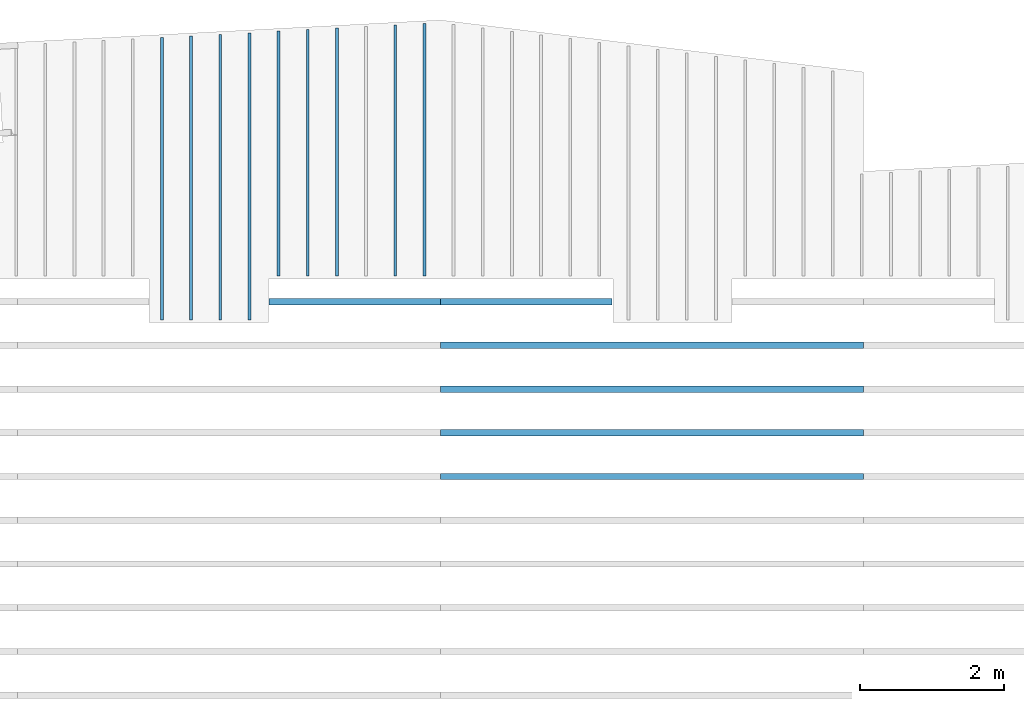
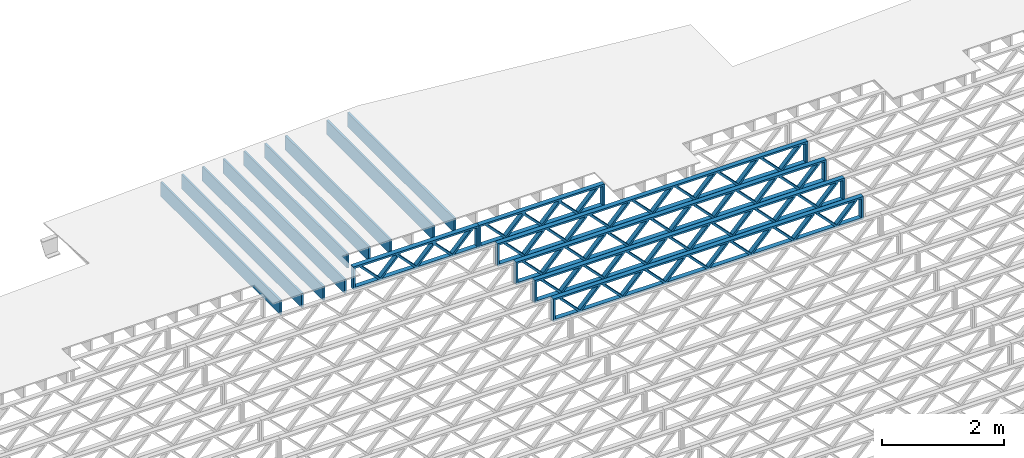
# One storey, part 8 of 13: 15 beams, 3 elements without a shape of their own.
"""IFC4 building model written with IfcOpenShell, lengths in feet."""

from ifc_helpers import new_model, entity, si_unit, converted_unit, derived_unit, direction, frame, frame_2d, origin, origin_2d_with_axis, place, context, subcontext, project, spatial, rectangle, extrude, source, transform, mapped, material, material_profile, profile_set, profile_usage, type_object, type_shapes, element, aggregate, save


model = new_model("IFC4")

# Units and contexts
model_context_1 = context("Model", 3, precision=0.0001, world=origin(), true_north=direction((6.12303176911189e-17, 1.0)))
model_context_2 = context("Model", 3, precision=0.0001, world=origin(), true_north=direction((6.12303176911189e-17, 1.0)))
body_context = subcontext(model_context_2, "Body", "Model", "MODEL_VIEW")
ifc_project = project(units=[converted_unit("LENGTHUNIT", "FOOT", entity("IfcRatioMeasure", 0.3048), si_unit("LENGTHUNIT", "METRE"), dimensions=[1, 0, 0, 0, 0, 0, 0]), converted_unit("AREAUNIT", "SQUARE FOOT", entity("IfcRatioMeasure", 0.09290304), si_unit("AREAUNIT", "SQUARE_METRE"), dimensions=[2, 0, 0, 0, 0, 0, 0]), converted_unit("VOLUMEUNIT", "CUBIC FOOT", entity("IfcRatioMeasure", 0.028316846592), si_unit("VOLUMEUNIT", "CUBIC_METRE"), dimensions=[3, 0, 0, 0, 0, 0, 0]), converted_unit("PLANEANGLEUNIT", "DEGREE", entity("IfcRatioMeasure", 0.0174532925199433), si_unit("PLANEANGLEUNIT", "RADIAN"), dimensions=[0, 0, 0, 0, 0, 0, 0]), si_unit("MASSUNIT", "GRAM", prefix="KILO"), derived_unit("MASSDENSITYUNIT", [(si_unit("MASSUNIT", "GRAM", prefix="KILO"), 1), (si_unit("LENGTHUNIT", "METRE"), -3)]), derived_unit("MOMENTOFINERTIAUNIT", [(si_unit("LENGTHUNIT", "METRE"), 4)]), si_unit("TIMEUNIT", "SECOND"), si_unit("FREQUENCYUNIT", "HERTZ"), si_unit("THERMODYNAMICTEMPERATUREUNIT", "DEGREE_CELSIUS"), derived_unit("THERMALTRANSMITTANCEUNIT", [(si_unit("MASSUNIT", "GRAM", prefix="KILO"), 1), (si_unit("THERMODYNAMICTEMPERATUREUNIT", "KELVIN"), -1), (si_unit("TIMEUNIT", "SECOND"), -3)]), derived_unit("VOLUMETRICFLOWRATEUNIT", [(si_unit("LENGTHUNIT", "METRE"), 3), (si_unit("TIMEUNIT", "SECOND"), -1)]), si_unit("ELECTRICCURRENTUNIT", "AMPERE"), si_unit("ELECTRICVOLTAGEUNIT", "VOLT"), si_unit("POWERUNIT", "WATT"), si_unit("FORCEUNIT", "NEWTON"), si_unit("ILLUMINANCEUNIT", "LUX"), si_unit("LUMINOUSFLUXUNIT", "LUMEN"), si_unit("LUMINOUSINTENSITYUNIT", "CANDELA"), derived_unit("USERDEFINED", [(si_unit("MASSUNIT", "GRAM", prefix="KILO"), -1), (si_unit("LENGTHUNIT", "METRE"), -2), (si_unit("TIMEUNIT", "SECOND"), 3), (si_unit("LUMINOUSFLUXUNIT", "LUMEN"), 1)]), derived_unit("LINEARVELOCITYUNIT", [(si_unit("LENGTHUNIT", "METRE"), 1), (si_unit("TIMEUNIT", "SECOND"), -1)]), si_unit("PRESSUREUNIT", "PASCAL"), derived_unit("USERDEFINED", [(si_unit("LENGTHUNIT", "METRE"), -2), (si_unit("MASSUNIT", "GRAM", prefix="KILO"), 1), (si_unit("TIMEUNIT", "SECOND"), -2)]), derived_unit("LINEARFORCEUNIT", [(si_unit("MASSUNIT", "GRAM", prefix="KILO"), 1), (si_unit("LENGTHUNIT", "METRE"), 1), (si_unit("TIMEUNIT", "SECOND"), -2), (si_unit("LENGTHUNIT", "METRE"), -1)]), derived_unit("PLANARFORCEUNIT", [(si_unit("MASSUNIT", "GRAM", prefix="KILO"), 1), (si_unit("LENGTHUNIT", "METRE"), 1), (si_unit("TIMEUNIT", "SECOND"), -2), (si_unit("LENGTHUNIT", "METRE"), -2)])], contexts=[model_context_1])

# Site, building, storey
site_placement = place(None, origin())
site = spatial("IfcSite", under=ifc_project, at=site_placement, CompositionType="ELEMENT")
building_placement = place(site_placement, origin())
building = spatial("IfcBuilding", under=site, at=building_placement, CompositionType="ELEMENT")
storey_placement = place(building_placement, frame((0.0, 0.0, 21.46875)))
storey = spatial("IfcBuildingStorey", under=building, at=storey_placement, Name="3RD FLOOR", CompositionType="ELEMENT", Elevation=21.46875)

# Assembly, beams
assembly_1_placement = place(storey_placement, origin())
assembly_1 = element("IfcElementAssembly", 1, at=assembly_1_placement, inside=storey, Name="Structural Beam System:Structural Framing System", ObjectType="Structural Beam System:Structural Framing System", AssemblyPlace="NOTDEFINED", PredefinedType="BEAM_GRID")
ifc_material_1 = material(Name="WOOD TRUSS", Category="Materials")
ifc_material_profile_1 = material_profile(ifc_material_1, rectangle(XDim=1.73473973950632, YDim=0.125, at=frame_2d((-1.11022302462516e-16, 8.32667268468867e-17), x_axis=(1.0, 0.0))))
ifc_material_profile_2 = material_profile(ifc_material_1, rectangle(XDim=1.73473973950633, YDim=0.125, at=frame_2d((-1.11022302462516e-16, 8.32667268468867e-17), x_axis=(1.0, 0.0))))
ifc_material_profile_3 = material_profile(ifc_material_1, rectangle(XDim=1.73473973950632, YDim=0.125, at=frame_2d((-5.55111512312578e-17, 1.38777878078145e-16), x_axis=(1.0, 0.0))))
ifc_material_profile_4 = material_profile(ifc_material_1, rectangle(XDim=1.73473973950633, YDim=0.125, at=frame_2d((-1.11022302462516e-16, 8.32667268468867e-17), x_axis=(1.0, 0.0))))
ifc_material_profile_5 = material_profile(ifc_material_1, rectangle(XDim=1.73473973950632, YDim=0.125, at=frame_2d((-1.11022302462516e-16, 8.32667268468867e-17), x_axis=(1.0, 0.0))))
ifc_material_profile_6 = material_profile(ifc_material_1, rectangle(XDim=1.73473973950633, YDim=0.125, at=frame_2d((-2.77555756156289e-16, 3.05311331771918e-16), x_axis=(1.0, 0.0))))
ifc_material_profile_7 = material_profile(ifc_material_1, rectangle(XDim=1.73473973950632, YDim=0.124999999999999, at=frame_2d((-3.88578058618805e-16, -2.4980018054066e-16), x_axis=(1.0, 0.0))))
ifc_material_profile_8 = material_profile(ifc_material_1, rectangle(XDim=1.73473973950633, YDim=0.125, at=frame_2d((2.77555756156289e-16, -3.05311331771918e-16), x_axis=(1.0, 0.0))))
ifc_material_profile_9 = material_profile(ifc_material_1, rectangle(XDim=1.73473973950632, YDim=0.124999999999999, at=frame_2d((-1.11022302462516e-16, 8.32667268468867e-17), x_axis=(1.0, 0.0))))
ifc_material_profile_10 = material_profile(ifc_material_1, rectangle(XDim=1.73473973950633, YDim=0.125, at=origin_2d_with_axis()))
ifc_material_profile_11 = material_profile(ifc_material_1, rectangle(XDim=0.124999999999982, YDim=0.291666666666668, at=origin_2d_with_axis()))
ifc_material_profile_12 = material_profile(ifc_material_1, rectangle(XDim=0.124999999999932, YDim=0.291666666666664, at=origin_2d_with_axis()))
ifc_material_profile_13 = material_profile(ifc_material_1, rectangle(XDim=1.25000000000002, YDim=0.29166666666667, at=origin_2d_with_axis()))
ifc_material_profile_14 = material_profile(ifc_material_1, rectangle(XDim=1.25000000000004, YDim=0.291666666666667, at=origin_2d_with_axis()))
ifc_profile_set_1 = profile_set([ifc_material_profile_1, ifc_material_profile_2, ifc_material_profile_3, ifc_material_profile_4, ifc_material_profile_5, ifc_material_profile_6, ifc_material_profile_7, ifc_material_profile_8, ifc_material_profile_9, ifc_material_profile_10, ifc_material_profile_11, ifc_material_profile_12, ifc_material_profile_13, ifc_material_profile_14])
ifc_profile_usage_1 = profile_usage(ifc_profile_set_1, cardinal=8)
beam_type_1 = type_object("IfcBeamType", PredefinedType="BEAM", material=ifc_profile_set_1)
shared_shape_1 = source(origin(), body_context, "Body", "SweptSolid", [
    extrude(rectangle(XDim=1.73473973950632, YDim=0.124999999999999, at=frame_2d((5.55111512312578e-16, 7.21644966006352e-16), x_axis=(1.0, 0.0))), frame((5.95847627016989, -0.145833333333334, 0.0), z_axis=(0.0, 1.0, 0.0), x_axis=(0.693383046997606, 0.0, 0.720569184836762)), (0.0, 0.0, 1.0), 0.291666666666667),
    extrude(rectangle(XDim=1.73473973950633, YDim=0.125, at=origin_2d_with_axis()), frame((4.70819039649662, -0.145833333333334, 0.0), z_axis=(0.0, 1.0, 0.0), x_axis=(0.69338304699761, 0.0, -0.720569184836758)), (0.0, 0.0, 1.0), 0.291666666666666),
    extrude(rectangle(XDim=1.73473973950632, YDim=0.125, at=frame_2d((2.22044604925031e-16, 3.88578058618805e-16), x_axis=(1.0, 0.0))), frame((3.29180960350342, -0.145833333333334, 0.0), z_axis=(0.0, 1.0, 0.0), x_axis=(0.693383046997606, 0.0, 0.720569184836762)), (0.0, 0.0, 1.0), 0.291666666666667),
    extrude(rectangle(XDim=1.73473973950633, YDim=0.125, at=frame_2d((1.11022302462516e-16, -8.32667268468867e-17), x_axis=(1.0, 0.0))), frame((2.04152372983015, -0.145833333333334, 0.0), z_axis=(0.0, 1.0, 0.0), x_axis=(0.69338304699761, 0.0, -0.720569184836758)), (0.0, 0.0, 1.0), 0.291666666666667),
    extrude(rectangle(XDim=1.73473973950632, YDim=0.125, at=frame_2d((-5.55111512312578e-17, 1.38777878078145e-16), x_axis=(1.0, 0.0))), frame((0.625142936836964, -0.145833333333334, 0.0), z_axis=(0.0, 1.0, 0.0), x_axis=(0.693383046997606, 0.0, 0.720569184836762)), (0.0, 0.0, 1.0), 0.291666666666667),
    extrude(rectangle(XDim=1.73473973950633, YDim=0.125, at=frame_2d((-1.11022302462516e-16, 8.32667268468867e-17), x_axis=(1.0, 0.0))), frame((-0.625142936836306, -0.145833333333334, 0.0), z_axis=(0.0, 1.0, 0.0), x_axis=(0.69338304699761, 0.0, -0.720569184836758)), (0.0, 0.0, 1.0), 0.291666666666667),
    extrude(rectangle(XDim=1.73473973950632, YDim=0.125, at=frame_2d((-1.11022302462516e-16, 8.32667268468867e-17), x_axis=(1.0, 0.0))), frame((-2.0415237298295, -0.145833333333334, 0.0), z_axis=(0.0, 1.0, 0.0), x_axis=(0.693383046997606, 0.0, 0.720569184836762)), (0.0, 0.0, 1.0), 0.291666666666667),
    extrude(rectangle(XDim=1.73473973950633, YDim=0.125, at=origin_2d_with_axis()), frame((-3.29180960350277, -0.145833333333334, 0.0), z_axis=(0.0, 1.0, 0.0), x_axis=(0.69338304699761, 0.0, -0.720569184836758)), (0.0, 0.0, 1.0), 0.291666666666667),
    extrude(rectangle(XDim=1.73473973950632, YDim=0.124999999999999, at=frame_2d((-1.11022302462516e-16, 8.32667268468867e-17), x_axis=(1.0, 0.0))), frame((-4.70819039649596, -0.145833333333334, 0.0), z_axis=(0.0, 1.0, 0.0), x_axis=(0.693383046997606, 0.0, 0.720569184836762)), (0.0, 0.0, 1.0), 0.291666666666667),
    extrude(rectangle(XDim=1.73473973950633, YDim=0.125, at=frame_2d((-5.55111512312578e-16, 6.38378239159465e-16), x_axis=(1.0, 0.0))), frame((-5.95847627016923, -0.145833333333334, 0.0), z_axis=(0.0, 1.0, 0.0), x_axis=(0.69338304699761, 0.0, -0.720569184836758)), (0.0, 0.0, 1.0), 0.291666666666666),
    extrude(rectangle(XDim=1.73473973950632, YDim=0.125, at=frame_2d((-7.21644966006352e-16, -5.82867087928207e-16), x_axis=(1.0, 0.0))), frame((8.62514293683635, -0.145833333333334, 0.0), z_axis=(0.0, 1.0, 0.0), x_axis=(0.693383046997607, 0.0, 0.720569184836761)), (0.0, 0.0, 1.0), 0.291666666666667),
    extrude(rectangle(XDim=1.73473973950633, YDim=0.125, at=origin_2d_with_axis()), frame((7.37485706316307, -0.145833333333334, 0.0), z_axis=(0.0, 1.0, 0.0), x_axis=(0.69338304699761, 0.0, -0.720569184836758)), (0.0, 0.0, 1.0), 0.291666666666666),
    extrude(rectangle(XDim=1.73473973950632, YDim=0.124999999999999, at=frame_2d((-1.11022302462516e-16, 8.32667268468867e-17), x_axis=(1.0, 0.0))), frame((-7.37485706316242, -0.145833333333334, 0.0), z_axis=(0.0, 1.0, 0.0), x_axis=(0.693383046997606, 0.0, 0.720569184836762)), (0.0, 0.0, 1.0), 0.291666666666667),
    extrude(rectangle(XDim=1.73473973950633, YDim=0.125, at=origin_2d_with_axis()), frame((-8.62514293683569, -0.145833333333334, 0.0), z_axis=(0.0, 1.0, 0.0), x_axis=(0.69338304699761, 0.0, -0.720569184836758)), (0.0, 0.0, 1.0), 0.291666666666666),
    extrude(rectangle(XDim=0.124999999999982, YDim=0.291666666666668, at=origin_2d_with_axis()), frame((-9.66666666666596, 0.0, 0.687500000000054), z_axis=(1.0, 0.0, 0.0), x_axis=(0.0, 0.0, -1.0)), (0.0, 0.0, 1.0), 19.3333333333319),
    extrude(rectangle(XDim=0.124999999999932, YDim=0.291666666666664, at=origin_2d_with_axis()), frame((-9.66666666666575, 0.0, -0.687499999999984), z_axis=(1.0, 0.0, 0.0), x_axis=(0.0, 0.0, -1.0)), (0.0, 0.0, 1.0), 19.3333333333317),
    extrude(rectangle(XDim=1.25000000000002, YDim=0.29166666666667, at=origin_2d_with_axis()), frame((9.54166666666594, 0.0, 0.0), z_axis=(1.0, 0.0, 0.0), x_axis=(0.0, 0.0, -1.0)), (0.0, 0.0, 1.0), 0.12500000000002),
    extrude(rectangle(XDim=1.25000000000004, YDim=0.291666666666667, at=origin_2d_with_axis()), frame((-9.66666666666596, 0.0, 0.0), z_axis=(1.0, 0.0, 0.0), x_axis=(0.0, 0.0, -1.0)), (0.0, 0.0, 1.0), 0.125000000000023),
])
type_shapes(beam_type_1, [shared_shape_1])
beam_1_placement = place(assembly_1_placement, frame((-193.404827152229, 955.861934882651, -0.947916666666881)))
beam_1 = element("IfcBeam", 2, at=beam_1_placement, type_object=beam_type_1, material=ifc_profile_usage_1, PredefinedType="BEAM", context=body_context, shape_type="MappedRepresentation", body=[
    mapped(shared_shape_1, transform((0.0, 0.0, 0.0), scale=1.0)),
])
ifc_profile_usage_2 = profile_usage(ifc_profile_set_1, cardinal=8)
beam_type_2 = type_object("IfcBeamType", PredefinedType="BEAM", material=ifc_profile_set_1)
shared_shape_2 = source(origin(), body_context, "Body", "SweptSolid", [
    extrude(rectangle(XDim=1.73473973950632, YDim=0.124999999999999, at=frame_2d((5.55111512312578e-16, 7.21644966006352e-16), x_axis=(1.0, 0.0))), frame((5.95847627016997, -0.145833333333334, 0.0), z_axis=(0.0, 1.0, 0.0), x_axis=(0.693383046997606, 0.0, 0.720569184836762)), (0.0, 0.0, 1.0), 0.291666666666667),
    extrude(rectangle(XDim=1.73473973950633, YDim=0.125, at=origin_2d_with_axis()), frame((4.7081903964967, -0.145833333333334, 0.0), z_axis=(0.0, 1.0, 0.0), x_axis=(0.69338304699761, 0.0, -0.720569184836758)), (0.0, 0.0, 1.0), 0.291666666666666),
    extrude(rectangle(XDim=1.73473973950632, YDim=0.125, at=frame_2d((2.22044604925031e-16, 3.88578058618805e-16), x_axis=(1.0, 0.0))), frame((3.29180960350347, -0.145833333333334, 0.0), z_axis=(0.0, 1.0, 0.0), x_axis=(0.693383046997606, 0.0, 0.720569184836762)), (0.0, 0.0, 1.0), 0.291666666666667),
    extrude(rectangle(XDim=1.73473973950633, YDim=0.125, at=frame_2d((1.11022302462516e-16, -8.32667268468867e-17), x_axis=(1.0, 0.0))), frame((2.0415237298302, -0.145833333333334, 0.0), z_axis=(0.0, 1.0, 0.0), x_axis=(0.69338304699761, 0.0, -0.720569184836758)), (0.0, 0.0, 1.0), 0.291666666666667),
    extrude(rectangle(XDim=1.73473973950632, YDim=0.125, at=frame_2d((-5.55111512312578e-17, 1.38777878078145e-16), x_axis=(1.0, 0.0))), frame((0.625142936836964, -0.145833333333334, 0.0), z_axis=(0.0, 1.0, 0.0), x_axis=(0.693383046997606, 0.0, 0.720569184836762)), (0.0, 0.0, 1.0), 0.291666666666667),
    extrude(rectangle(XDim=1.73473973950633, YDim=0.125, at=frame_2d((-1.11022302462516e-16, 8.32667268468867e-17), x_axis=(1.0, 0.0))), frame((-0.625142936836306, -0.145833333333334, 0.0), z_axis=(0.0, 1.0, 0.0), x_axis=(0.69338304699761, 0.0, -0.720569184836758)), (0.0, 0.0, 1.0), 0.291666666666667),
    extrude(rectangle(XDim=1.73473973950632, YDim=0.125, at=frame_2d((-1.11022302462516e-16, 8.32667268468867e-17), x_axis=(1.0, 0.0))), frame((-2.04152372982954, -0.145833333333334, 0.0), z_axis=(0.0, 1.0, 0.0), x_axis=(0.693383046997606, 0.0, 0.720569184836762)), (0.0, 0.0, 1.0), 0.291666666666667),
    extrude(rectangle(XDim=1.73473973950633, YDim=0.125, at=origin_2d_with_axis()), frame((-3.29180960350281, -0.145833333333334, 0.0), z_axis=(0.0, 1.0, 0.0), x_axis=(0.69338304699761, 0.0, -0.720569184836758)), (0.0, 0.0, 1.0), 0.291666666666667),
    extrude(rectangle(XDim=1.73473973950632, YDim=0.124999999999999, at=frame_2d((-1.11022302462516e-16, 8.32667268468867e-17), x_axis=(1.0, 0.0))), frame((-4.70819039649604, -0.145833333333334, 0.0), z_axis=(0.0, 1.0, 0.0), x_axis=(0.693383046997606, 0.0, 0.720569184836762)), (0.0, 0.0, 1.0), 0.291666666666667),
    extrude(rectangle(XDim=1.73473973950633, YDim=0.125, at=frame_2d((-5.55111512312578e-16, 6.38378239159465e-16), x_axis=(1.0, 0.0))), frame((-5.95847627016931, -0.145833333333334, 0.0), z_axis=(0.0, 1.0, 0.0), x_axis=(0.69338304699761, 0.0, -0.720569184836758)), (0.0, 0.0, 1.0), 0.291666666666666),
    extrude(rectangle(XDim=1.73473973950632, YDim=0.125, at=frame_2d((-7.21644966006352e-16, -5.82867087928207e-16), x_axis=(1.0, 0.0))), frame((8.62514293683647, -0.145833333333334, 0.0), z_axis=(0.0, 1.0, 0.0), x_axis=(0.693383046997607, 0.0, 0.720569184836761)), (0.0, 0.0, 1.0), 0.291666666666667),
    extrude(rectangle(XDim=1.73473973950633, YDim=0.125, at=origin_2d_with_axis()), frame((7.3748570631632, -0.145833333333334, 0.0), z_axis=(0.0, 1.0, 0.0), x_axis=(0.69338304699761, 0.0, -0.720569184836758)), (0.0, 0.0, 1.0), 0.291666666666666),
    extrude(rectangle(XDim=1.73473973950632, YDim=0.124999999999999, at=frame_2d((-1.11022302462516e-16, 8.32667268468867e-17), x_axis=(1.0, 0.0))), frame((-7.37485706316255, -0.145833333333334, 0.0), z_axis=(0.0, 1.0, 0.0), x_axis=(0.693383046997606, 0.0, 0.720569184836762)), (0.0, 0.0, 1.0), 0.291666666666667),
    extrude(rectangle(XDim=1.73473973950633, YDim=0.125, at=origin_2d_with_axis()), frame((-8.62514293683582, -0.145833333333334, 0.0), z_axis=(0.0, 1.0, 0.0), x_axis=(0.69338304699761, 0.0, -0.720569184836758)), (0.0, 0.0, 1.0), 0.291666666666666),
    extrude(rectangle(XDim=0.124999999999982, YDim=0.291666666666668, at=origin_2d_with_axis()), frame((-9.66666666666609, 0.0, 0.687500000000054), z_axis=(1.0, 0.0, 0.0), x_axis=(0.0, 0.0, -1.0)), (0.0, 0.0, 1.0), 19.3333333333322),
    extrude(rectangle(XDim=0.124999999999932, YDim=0.291666666666664, at=origin_2d_with_axis()), frame((-9.66666666666588, 0.0, -0.687499999999984), z_axis=(1.0, 0.0, 0.0), x_axis=(0.0, 0.0, -1.0)), (0.0, 0.0, 1.0), 19.333333333332),
    extrude(rectangle(XDim=1.25000000000002, YDim=0.29166666666667, at=origin_2d_with_axis()), frame((9.54166666666607, 0.0, 0.0), z_axis=(1.0, 0.0, 0.0), x_axis=(0.0, 0.0, -1.0)), (0.0, 0.0, 1.0), 0.12500000000002),
    extrude(rectangle(XDim=1.25000000000004, YDim=0.291666666666667, at=origin_2d_with_axis()), frame((-9.66666666666609, 0.0, 0.0), z_axis=(1.0, 0.0, 0.0), x_axis=(0.0, 0.0, -1.0)), (0.0, 0.0, 1.0), 0.125000000000023),
])
type_shapes(beam_type_2, [shared_shape_2])
beam_2_placement = place(assembly_1_placement, frame((-193.404827152229, 953.861934882651, -0.947916666666881)))
beam_2 = element("IfcBeam", 3, at=beam_2_placement, type_object=beam_type_2, material=ifc_profile_usage_2, PredefinedType="BEAM", context=body_context, shape_type="MappedRepresentation", body=[
    mapped(shared_shape_2, transform((0.0, 0.0, 0.0), scale=1.0)),
])
ifc_profile_usage_3 = profile_usage(ifc_profile_set_1, cardinal=8)
beam_3_placement = place(assembly_1_placement, frame((-193.404827152229, 951.861934882651, -0.947916666666881)))
beam_3 = element("IfcBeam", 4, at=beam_3_placement, type_object=beam_type_2, material=ifc_profile_usage_3, PredefinedType="BEAM", context=body_context, shape_type="MappedRepresentation", body=[
    mapped(shared_shape_2, transform((0.0, 0.0, 0.0), scale=1.0)),
])
ifc_profile_usage_4 = profile_usage(ifc_profile_set_1, cardinal=8)
beam_4_placement = place(assembly_1_placement, frame((-193.404827152229, 949.861934882651, -0.947916666666881)))
beam_4 = element("IfcBeam", 5, at=beam_4_placement, type_object=beam_type_2, material=ifc_profile_usage_4, PredefinedType="BEAM", context=body_context, shape_type="MappedRepresentation", body=[
    mapped(shared_shape_2, transform((0.0, 0.0, 0.0), scale=1.0)),
])

assembly_2_placement = place(storey_placement, origin())
assembly_2 = element("IfcElementAssembly", 6, at=assembly_2_placement, inside=storey, Name="Structural Beam System:Structural Framing System", ObjectType="Structural Beam System:Structural Framing System", AssemblyPlace="NOTDEFINED", PredefinedType="BEAM_GRID")
ifc_material_2 = material(Category="Materials")
ifc_material_profile_15 = material_profile(ifc_material_2, rectangle(XDim=0.9375, YDim=0.125000000000011, at=origin_2d_with_axis()))
ifc_profile_set_2 = profile_set([ifc_material_profile_15])
ifc_profile_usage_5 = profile_usage(ifc_profile_set_2, cardinal=8)
beam_type_3 = type_object("IfcBeamType", PredefinedType="BEAM", material=ifc_profile_set_2)
shared_shape_3 = source(origin(), body_context, "Body", "SweptSolid", [
    extrude(rectangle(XDim=0.9375, YDim=0.125000000000011, at=origin_2d_with_axis()), frame((-5.77162268447722, 0.0, 0.0), z_axis=(1.0, 0.0, 0.0), x_axis=(0.0, 0.0, -1.0)), (0.0, 0.0, 1.0), 11.5432453689544),
])
type_shapes(beam_type_3, [shared_shape_3])
beam_5_placement = place(assembly_2_placement, frame((-203.810956052701, 964.80022192447, -0.729166666666714), z_axis=(0.0, 0.0, 1.0), x_axis=(0.0, 1.0, 0.0)))
beam_5 = element("IfcBeam", 7, at=beam_5_placement, type_object=beam_type_3, material=ifc_profile_usage_5, PredefinedType="BEAM", context=body_context, shape_type="MappedRepresentation", body=[
    mapped(shared_shape_3, transform((0.0, 0.0, 0.0), scale=1.0)),
])
ifc_profile_usage_6 = profile_usage(ifc_profile_set_2, cardinal=8)
beam_type_4 = type_object("IfcBeamType", PredefinedType="BEAM", material=ifc_profile_set_2)
shared_shape_4 = source(origin(), body_context, "Body", "SweptSolid", [
    extrude(rectangle(XDim=0.9375, YDim=0.125000000000011, at=origin_2d_with_axis()), frame((-5.7366843325334, 0.0, 0.0), z_axis=(1.0, 0.0, 0.0), x_axis=(0.0, 0.0, -1.0)), (0.0, 0.0, 1.0), 11.4733686650668),
])
type_shapes(beam_type_4, [shared_shape_4])
beam_6_placement = place(assembly_2_placement, frame((-205.144289386034, 964.765283237369, -0.729166666666714), z_axis=(0.0, 0.0, 1.0), x_axis=(0.0, 1.0, 0.0)))
beam_6 = element("IfcBeam", 8, at=beam_6_placement, type_object=beam_type_4, material=ifc_profile_usage_6, PredefinedType="BEAM", context=body_context, shape_type="MappedRepresentation", body=[
    mapped(shared_shape_4, transform((0.0, 0.0, 0.0), scale=1.0)),
])
ifc_profile_usage_7 = profile_usage(ifc_profile_set_2, cardinal=8)
beam_type_5 = type_object("IfcBeamType", PredefinedType="BEAM", material=ifc_profile_set_2)
shared_shape_5 = source(origin(), body_context, "Body", "SweptSolid", [
    extrude(rectangle(XDim=0.9375, YDim=0.125000000000011, at=origin_2d_with_axis()), frame((-5.66680762864587, 0.0, 0.0), z_axis=(1.0, 0.0, 0.0), x_axis=(0.0, 0.0, -1.0)), (0.0, 0.0, 1.0), 11.3336152572917),
])
type_shapes(beam_type_5, [shared_shape_5])
beam_7_placement = place(assembly_2_placement, frame((-207.810956052701, 964.695405863169, -0.729166666666714), z_axis=(0.0, 0.0, 1.0), x_axis=(0.0, 1.0, 0.0)))
beam_7 = element("IfcBeam", 9, at=beam_7_placement, type_object=beam_type_5, material=ifc_profile_usage_7, PredefinedType="BEAM", context=body_context, shape_type="MappedRepresentation", body=[
    mapped(shared_shape_5, transform((0.0, 0.0, 0.0), scale=1.0)),
])
ifc_profile_usage_8 = profile_usage(ifc_profile_set_2, cardinal=8)
beam_type_6 = type_object("IfcBeamType", PredefinedType="BEAM", material=ifc_profile_set_2)
shared_shape_6 = source(origin(), body_context, "Body", "SweptSolid", [
    extrude(rectangle(XDim=0.9375, YDim=0.125000000000011, at=origin_2d_with_axis()), frame((-5.59693092475834, 0.0, 0.0), z_axis=(1.0, 0.0, 0.0), x_axis=(0.0, 0.0, -1.0)), (0.0, 0.0, 1.0), 11.1938618495167),
])
type_shapes(beam_type_6, [shared_shape_6])
beam_8_placement = place(assembly_2_placement, frame((-210.477622719368, 964.625528488969, -0.729166666666714), z_axis=(0.0, 0.0, 1.0), x_axis=(0.0, 1.0, 0.0)))
beam_8 = element("IfcBeam", 10, at=beam_8_placement, type_object=beam_type_6, material=ifc_profile_usage_8, PredefinedType="BEAM", context=body_context, shape_type="MappedRepresentation", body=[
    mapped(shared_shape_6, transform((0.0, 0.0, 0.0), scale=1.0)),
])
ifc_profile_usage_9 = profile_usage(ifc_profile_set_2, cardinal=8)
beam_type_7 = type_object("IfcBeamType", PredefinedType="BEAM", material=ifc_profile_set_2)
shared_shape_7 = source(origin(), body_context, "Body", "SweptSolid", [
    extrude(rectangle(XDim=0.9375, YDim=0.125000000000011, at=origin_2d_with_axis()), frame((-6.52659455763063, 0.0, 0.0), z_axis=(1.0, 0.0, 0.0), x_axis=(0.0, 0.0, -1.0)), (0.0, 0.0, 1.0), 13.0531891152613),
])
type_shapes(beam_type_7, [shared_shape_7])
beam_9_placement = place(assembly_2_placement, frame((-213.144289386034, 963.556110778009, -0.729166666666714), z_axis=(0.0, 0.0, 1.0), x_axis=(0.0, 1.0, 0.0)))
beam_9 = element("IfcBeam", 11, at=beam_9_placement, type_object=beam_type_7, material=ifc_profile_usage_9, PredefinedType="BEAM", context=body_context, shape_type="MappedRepresentation", body=[
    mapped(shared_shape_7, transform((0.0, 0.0, 0.0), scale=1.0)),
])
ifc_profile_usage_10 = profile_usage(ifc_profile_set_2, cardinal=8)
beam_type_8 = type_object("IfcBeamType", PredefinedType="BEAM", material=ifc_profile_set_2)
shared_shape_8 = source(origin(), body_context, "Body", "SweptSolid", [
    extrude(rectangle(XDim=0.9375, YDim=0.125000000000011, at=origin_2d_with_axis()), frame((-6.49165603810872, 0.0, 0.0), z_axis=(1.0, 0.0, 0.0), x_axis=(0.0, 0.0, -1.0)), (0.0, 0.0, 1.0), 12.9833120762174),
])
type_shapes(beam_type_8, [shared_shape_8])
beam_10_placement = place(assembly_2_placement, frame((-214.477622719368, 963.521172258487, -0.729166666666714), z_axis=(0.0, 0.0, 1.0), x_axis=(0.0, 1.0, 0.0)))
beam_10 = element("IfcBeam", 12, at=beam_10_placement, type_object=beam_type_8, material=ifc_profile_usage_10, PredefinedType="BEAM", context=body_context, shape_type="MappedRepresentation", body=[
    mapped(shared_shape_8, transform((0.0, 0.0, 0.0), scale=1.0)),
])
ifc_profile_usage_11 = profile_usage(ifc_profile_set_2, cardinal=8)
beam_type_9 = type_object("IfcBeamType", PredefinedType="BEAM", material=ifc_profile_set_2)
shared_shape_9 = source(origin(), body_context, "Body", "SweptSolid", [
    extrude(rectangle(XDim=0.9375, YDim=0.125000000000011, at=origin_2d_with_axis()), frame((-6.45671751858674, 0.0, 0.0), z_axis=(1.0, 0.0, 0.0), x_axis=(0.0, 0.0, -1.0)), (0.0, 0.0, 1.0), 12.9134350371735),
])
type_shapes(beam_type_9, [shared_shape_9])
beam_11_placement = place(assembly_2_placement, frame((-215.810956052701, 963.486233738965, -0.729166666666714), z_axis=(0.0, 0.0, 1.0), x_axis=(0.0, 1.0, 0.0)))
beam_11 = element("IfcBeam", 13, at=beam_11_placement, type_object=beam_type_9, material=ifc_profile_usage_11, PredefinedType="BEAM", context=body_context, shape_type="MappedRepresentation", body=[
    mapped(shared_shape_9, transform((0.0, 0.0, 0.0), scale=1.0)),
])
ifc_profile_usage_12 = profile_usage(ifc_profile_set_2, cardinal=8)
beam_type_10 = type_object("IfcBeamType", PredefinedType="BEAM", material=ifc_profile_set_2)
shared_shape_10 = source(origin(), body_context, "Body", "SweptSolid", [
    extrude(rectangle(XDim=0.9375, YDim=0.125000000000011, at=origin_2d_with_axis()), frame((-6.5615330771526, 0.0, 0.0), z_axis=(1.0, 0.0, 0.0), x_axis=(0.0, 0.0, -1.0)), (0.0, 0.0, 1.0), 13.1230661543052),
])
type_shapes(beam_type_10, [shared_shape_10])
beam_12_placement = place(assembly_2_placement, frame((-211.810956052701, 963.591049297531, -0.729166666666714), z_axis=(0.0, 0.0, 1.0), x_axis=(0.0, 1.0, 0.0)))
beam_12 = element("IfcBeam", 14, at=beam_12_placement, type_object=beam_type_10, material=ifc_profile_usage_12, PredefinedType="BEAM", context=body_context, shape_type="MappedRepresentation", body=[
    mapped(shared_shape_10, transform((0.0, 0.0, 0.0), scale=1.0)),
])
ifc_profile_usage_13 = profile_usage(ifc_profile_set_2, cardinal=8)
beam_type_11 = type_object("IfcBeamType", PredefinedType="BEAM", material=ifc_profile_set_2)
shared_shape_11 = source(origin(), body_context, "Body", "SweptSolid", [
    extrude(rectangle(XDim=0.9375, YDim=0.125000000000011, at=origin_2d_with_axis()), frame((-5.63186927670205, 0.0, 0.0), z_axis=(1.0, 0.0, 0.0), x_axis=(0.0, 0.0, -1.0)), (0.0, 0.0, 1.0), 11.2637385534041),
])
type_shapes(beam_type_11, [shared_shape_11])
beam_13_placement = place(assembly_2_placement, frame((-209.144289386034, 964.660467176069, -0.729166666666714), z_axis=(0.0, 0.0, 1.0), x_axis=(0.0, 1.0, 0.0)))
beam_13 = element("IfcBeam", 15, at=beam_13_placement, type_object=beam_type_11, material=ifc_profile_usage_13, PredefinedType="BEAM", context=body_context, shape_type="MappedRepresentation", body=[
    mapped(shared_shape_11, transform((0.0, 0.0, 0.0), scale=1.0)),
])
aggregate(assembly_2, [beam_5, beam_6, beam_7, beam_8, beam_9, beam_10, beam_11, beam_12, beam_13])

# Beam
ifc_profile_usage_14 = profile_usage(ifc_profile_set_1, cardinal=8)
beam_type_12 = type_object("IfcBeamType", PredefinedType="BEAM", material=ifc_profile_set_1)
shared_shape_12 = source(origin(), body_context, "Body", "SweptSolid", [
    extrude(rectangle(XDim=1.73473973950632, YDim=0.125, at=frame_2d((-5.55111512312578e-17, 1.38777878078145e-16), x_axis=(1.0, 0.0))), frame((0.625142936836963, -0.145833333333334, 0.0), z_axis=(0.0, 1.0, 0.0), x_axis=(0.693383046997606, 0.0, 0.720569184836762)), (0.0, 0.0, 1.0), 0.291666666666667),
    extrude(rectangle(XDim=1.73473973950633, YDim=0.125, at=frame_2d((-1.11022302462516e-16, 8.32667268468867e-17), x_axis=(1.0, 0.0))), frame((-0.625142936836308, -0.145833333333334, 0.0), z_axis=(0.0, 1.0, 0.0), x_axis=(0.69338304699761, 0.0, -0.720569184836758)), (0.0, 0.0, 1.0), 0.291666666666667),
    extrude(rectangle(XDim=1.73473973950632, YDim=0.125, at=frame_2d((-1.11022302462516e-16, 8.32667268468867e-17), x_axis=(1.0, 0.0))), frame((2.87514285312432, -0.145833333333334, 0.0), z_axis=(0.0, 1.0, 0.0), x_axis=(0.693383046997606, 0.0, 0.720569184836762)), (0.0, 0.0, 1.0), 0.291666666666667),
    extrude(rectangle(XDim=1.73473973950633, YDim=0.125, at=frame_2d((-1.11022302462516e-16, 8.32667268468867e-17), x_axis=(1.0, 0.0))), frame((1.62485697945105, -0.145833333333334, 0.0), z_axis=(0.0, 1.0, 0.0), x_axis=(0.69338304699761, 0.0, -0.720569184836758)), (0.0, 0.0, 1.0), 0.291666666666667),
    extrude(rectangle(XDim=1.73473973950632, YDim=0.125, at=frame_2d((-1.11022302462516e-16, 8.32667268468867e-17), x_axis=(1.0, 0.0))), frame((-1.62485697945039, -0.145833333333334, 0.0), z_axis=(0.0, 1.0, 0.0), x_axis=(0.693383046997606, 0.0, 0.720569184836762)), (0.0, 0.0, 1.0), 0.291666666666667),
    extrude(rectangle(XDim=1.73473973950633, YDim=0.125, at=origin_2d_with_axis()), frame((-2.87514285312366, -0.145833333333334, 0.0), z_axis=(0.0, 1.0, 0.0), x_axis=(0.69338304699761, 0.0, -0.720569184836758)), (0.0, 0.0, 1.0), 0.291666666666667),
    extrude(rectangle(XDim=0.124999999999982, YDim=0.291666666666668, at=origin_2d_with_axis()), frame((-3.91666658295394, 0.0, 0.687500000000054), z_axis=(1.0, 0.0, 0.0), x_axis=(0.0, 0.0, -1.0)), (0.0, 0.0, 1.0), 7.83333316590787),
    extrude(rectangle(XDim=0.124999999999932, YDim=0.291666666666664, at=origin_2d_with_axis()), frame((-3.91666658295372, 0.0, -0.687499999999984), z_axis=(1.0, 0.0, 0.0), x_axis=(0.0, 0.0, -1.0)), (0.0, 0.0, 1.0), 7.83333316590766),
    extrude(rectangle(XDim=1.25000000000002, YDim=0.29166666666667, at=origin_2d_with_axis()), frame((3.79166658295392, 0.0, 0.0), z_axis=(1.0, 0.0, 0.0), x_axis=(0.0, 0.0, -1.0)), (0.0, 0.0, 1.0), 0.12500000000002),
    extrude(rectangle(XDim=1.25000000000004, YDim=0.291666666666667, at=origin_2d_with_axis()), frame((-3.91666658295394, 0.0, 0.0), z_axis=(1.0, 0.0, 0.0), x_axis=(0.0, 0.0, -1.0)), (0.0, 0.0, 1.0), 0.125000000000023),
])
type_shapes(beam_type_12, [shared_shape_12])
beam_14_placement = place(assembly_1_placement, frame((-199.154827235941, 957.861934882651, -0.947916666666881)))
beam_14 = element("IfcBeam", 16, at=beam_14_placement, type_object=beam_type_12, material=ifc_profile_usage_14, PredefinedType="BEAM", context=body_context, shape_type="MappedRepresentation", body=[
    mapped(shared_shape_12, transform((0.0, 0.0, 0.0), scale=1.0)),
])

aggregate(assembly_1, [beam_1, beam_2, beam_3, beam_4, beam_14])

# Assembly, beam
assembly_3_placement = place(storey_placement, origin())
assembly_3 = element("IfcElementAssembly", 17, at=assembly_3_placement, inside=storey, Name="Structural Beam System:Structural Framing System", ObjectType="Structural Beam System:Structural Framing System", AssemblyPlace="NOTDEFINED", PredefinedType="BEAM_GRID")
ifc_profile_usage_15 = profile_usage(ifc_profile_set_1, cardinal=8)
beam_15_placement = place(assembly_3_placement, frame((-206.988160401783, 957.861934882651, -0.947916666666881), z_axis=(0.0, 0.0, 1.0), x_axis=(-1.0, 0.0, 0.0)))
beam_15 = element("IfcBeam", 18, at=beam_15_placement, type_object=beam_type_12, material=ifc_profile_usage_15, PredefinedType="BEAM", context=body_context, shape_type="MappedRepresentation", body=[
    mapped(shared_shape_12, transform((0.0, 0.0, 0.0), scale=1.0)),
])
aggregate(assembly_3, [beam_15])

save(model, "model.ifc")
